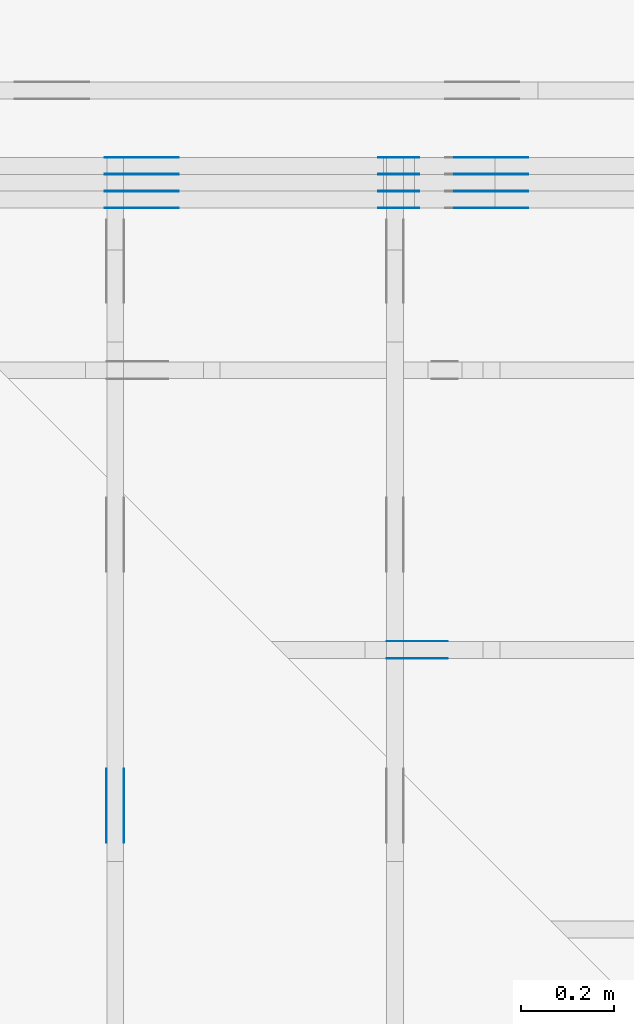
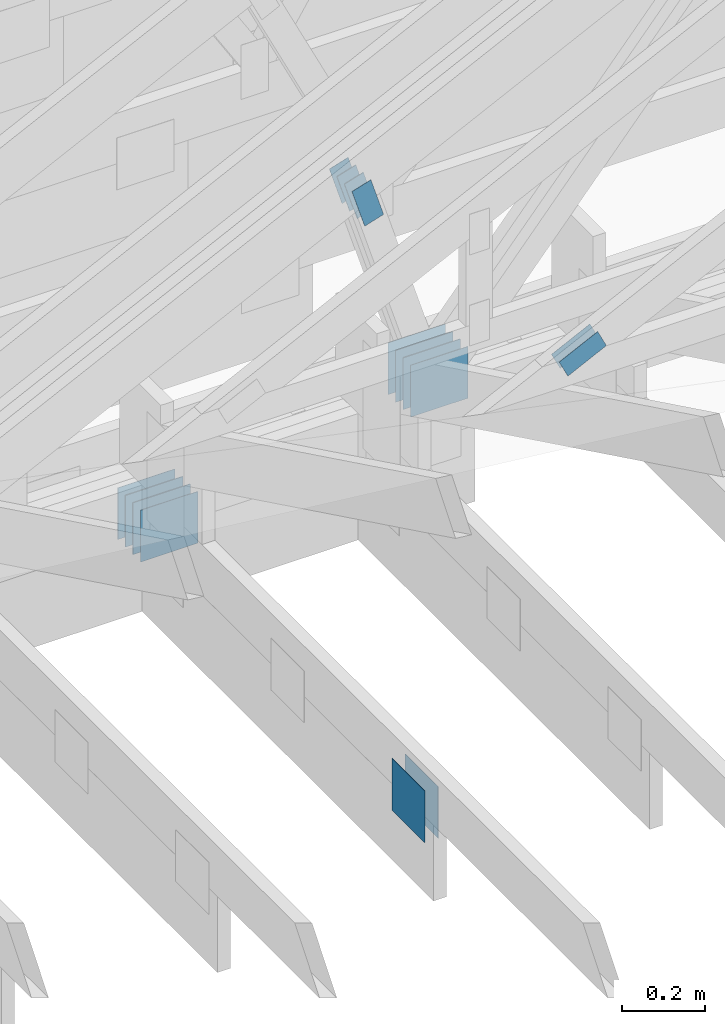
# One storey, part 99 of 159: 22 plates, 3 elements without a shape of their own.
"""IFC2X3 building model written with IfcOpenShell, lengths in millimetres."""

import ifcopenshell
import ifcopenshell.guid

model = None  # the IFC model being written
_history = None  # IfcOwnerHistory: only IFC2X3 demands one
_inside = {}  # id of a spatial element -> (the spatial element, [elements in it])
_under = {}  # id of a project, library or spatial element -> (it, [spatial elements below it])
_declared = {}  # id of a project -> (the project, [libraries it declares])
_typed = {}  # id of a type object -> (the type object, [elements of that type])
_made_of = {}  # id of a material, layer set ... -> (it, [elements and type objects made of it])


def new_model(schema):
    """Start an empty IFC model of exactly this schema.

    Asked for "IFC4X3", IfcOpenShell would pick the latest addendum, in which some entities
    have other attributes; the version numbers below select the first issue.
    IFC2X3 requires an IfcOwnerHistory on every rooted entity: one is made here for all.
    """
    global model, _history
    if schema == "IFC4X3":
        model = ifcopenshell.file(schema_version=(4, 3, 0, 0))
    else:
        model = ifcopenshell.file(schema=schema)
    _inside.clear()
    _under.clear()
    _declared.clear()
    _typed.clear()
    _made_of.clear()
    _history = None
    if model.schema == "IFC2X3":
        org = make("IfcOrganization", Name="unknown")
        user = make(
            "IfcPersonAndOrganization",
            ThePerson=make("IfcPerson", FamilyName="unknown"),
            TheOrganization=org,
        )
        app = make(
            "IfcApplication",
            ApplicationDeveloper=org,
            Version="unknown",
            ApplicationFullName="unknown",
            ApplicationIdentifier="unknown",
        )
        _history = make(
            "IfcOwnerHistory",
            OwningUser=user,
            OwningApplication=app,
            ChangeAction="ADDED",
            CreationDate=0,
        )
    return model


def make(cls, **values):
    """One entity of the class cls with the attributes given. An attribute that is None is left unset."""
    return model.create_entity(
        cls, **{name: value for name, value in values.items() if value is not None}
    )


def rooted(cls, **values):
    """An entity with a GlobalId (a new one), such as an element, a storey or a relation."""
    return make(cls, GlobalId=ifcopenshell.guid.new(), OwnerHistory=_history, **values)


def si_unit(unit_type, name, prefix=None):
    """IfcSIUnit, for example si_unit("LENGTHUNIT", "METRE", prefix="MILLI")."""
    return make("IfcSIUnit", UnitType=unit_type, Prefix=prefix, Name=name)


def assignment(units):
    """IfcUnitAssignment: the units of a project."""
    return None if units is None else make("IfcUnitAssignment", Units=units)


def point(xyz):
    """IfcCartesianPoint."""
    return None if xyz is None else make("IfcCartesianPoint", Coordinates=xyz)


def direction(xyz):
    """IfcDirection."""
    return None if xyz is None else make("IfcDirection", DirectionRatios=xyz)


def frame(location, z_axis=None, x_axis=None):
    """IfcAxis2Placement3D, a coordinate frame: its origin and axes. An axis left out is left unset."""
    return make(
        "IfcAxis2Placement3D",
        Location=point(location),
        Axis=direction(z_axis),
        RefDirection=direction(x_axis),
    )


def frame_2d(location, x_axis=None):
    """IfcAxis2Placement2D, a coordinate frame in the plane: its origin and x axis."""
    return make(
        "IfcAxis2Placement2D", Location=point(location), RefDirection=direction(x_axis)
    )


def origin():
    """The frame at (0, 0, 0) with its axes left unset."""
    return frame((0.0, 0.0, 0.0))


def origin_with_axes():
    """The frame at (0, 0, 0) with the z axis (0, 0, 1) and the x axis (1, 0, 0) written out."""
    return frame((0.0, 0.0, 0.0), z_axis=(0.0, 0.0, 1.0), x_axis=(1.0, 0.0, 0.0))


def origin_2d():
    """The frame at (0, 0) in the plane with its x axis left unset."""
    return frame_2d((0.0, 0.0))


def place(relative_to, where):
    """IfcLocalPlacement: puts the frame where relative to a parent placement (None: the world)."""
    return make(
        "IfcLocalPlacement", PlacementRelTo=relative_to, RelativePlacement=where
    )


def context(
    kind, dimensions, precision=None, world=None, true_north=None, identifier=None
):
    """IfcGeometricRepresentationContext, for example the 3D "Model" context."""
    return make(
        "IfcGeometricRepresentationContext",
        ContextIdentifier=identifier,
        ContextType=kind,
        CoordinateSpaceDimension=dimensions,
        Precision=precision,
        WorldCoordinateSystem=world,
        TrueNorth=true_north,
    )


def project(units=None, contexts=None):
    """IfcProject with its units and contexts."""
    return rooted(
        "IfcProject",
        Name="project",
        RepresentationContexts=contexts,
        UnitsInContext=assignment(units),
    )


def spatial(cls, under=None, at=None, **own):
    """A site, building, storey or space (cls), placed at a placement, below another one or the project."""
    s = rooted(cls, ObjectPlacement=at, **own)
    if under is not None:
        _under.setdefault(under.id(), (under, []))[1].append(s)
    return s


def faces_of(points, faces, orient=None, outer=None):
    """IfcFace entities. A face is a list of loops; a loop is a list of indices into points, from 0.

    orient and outer hold one flag for each loop. By default every Orientation is true, the
    first loop of a face is its IfcFaceOuterBound and the others are IfcFaceBound.
    """
    made = []
    for i, loops in enumerate(faces):
        bounds = []
        for j, loop in enumerate(loops):
            is_outer = j == 0 if outer is None else outer[i][j]
            bounds.append(
                make(
                    "IfcFaceOuterBound" if is_outer else "IfcFaceBound",
                    Bound=make("IfcPolyLoop", Polygon=[points[k] for k in loop]),
                    Orientation=True if orient is None else orient[i][j],
                )
            )
        made.append(make("IfcFace", Bounds=bounds))
    return made


def faceted_brep(points, faces, orient=None, outer=None, voids=None):
    """IfcFacetedBrep: a solid bounded by flat faces; with voids (closed shells), ...WithVoids."""
    shared = [point(p) for p in points]
    hull = make("IfcClosedShell", CfsFaces=faces_of(shared, faces, orient, outer))
    if voids is None:
        return make("IfcFacetedBrep", Outer=hull)
    return make(
        "IfcFacetedBrepWithVoids",
        Outer=hull,
        Voids=[
            make(cls, CfsFaces=faces_of(shared, fs, o, b)) for cls, fs, o, b in voids
        ],
    )


def shape(context_of_items, identifier, shape_type, items):
    """IfcShapeRepresentation: the items that make up one representation, for example the "Body"."""
    return make(
        "IfcShapeRepresentation",
        ContextOfItems=context_of_items,
        RepresentationIdentifier=identifier,
        RepresentationType=shape_type,
        Items=items,
    )


def made_of(thing, what):
    """Note that an element or type object is made of a material, layer set ...; save() writes the relation."""
    if what is not None:
        _made_of.setdefault(what.id(), (what, []))[1].append(thing)
    return thing


def element(
    cls,
    number,
    at=None,
    inside=None,
    cuts=None,
    type_object=None,
    material=None,
    context=None,
    identifier="Body",
    shape_type=None,
    held_by="IfcProductDefinitionShape",
    body=None,
    shapes=None,
    **own,
):
    """One element of the class cls, such as IfcWall. Its Tag is "e" and its number.

    at: its placement. inside: the storey or other place that contains it. cuts: it is an
    opening in that element (IfcRelVoidsElement). A single representation is given by context,
    identifier, shape_type and body (its items); several are given by shapes. held_by: the class
    of the entity that holds the representations. save() writes the other relations.
    """
    e = rooted(cls, Tag="e%d" % number, ObjectPlacement=at, **own)
    if body is not None:
        shapes = [shape(context, identifier, shape_type, body)]
    if shapes is not None:
        e.Representation = make(held_by, Representations=shapes)
    if inside is not None:
        _inside.setdefault(inside.id(), (inside, []))[1].append(e)
    if cuts is not None:
        rooted(
            "IfcRelVoidsElement", RelatingBuildingElement=cuts, RelatedOpeningElement=e
        )
    if type_object is not None:
        _typed.setdefault(type_object.id(), (type_object, []))[1].append(e)
    return made_of(e, material)


def aggregate(whole, parts):
    """IfcRelAggregates: a whole, such as a stair, and the parts it consists of."""
    return rooted("IfcRelAggregates", RelatingObject=whole, RelatedObjects=parts)


def save(model, path):
    """Write the relations noted so far, then the file.

    IfcRelAggregates (storeys below a building ...), IfcRelContainedInSpatialStructure (elements
    in a storey), IfcRelDefinesByType, IfcRelAssociatesMaterial and IfcRelDeclares: one each for
    every whole, place, type object, material and project.
    """
    for whole, parts in _under.values():
        aggregate(whole, parts)
    for where, things in _inside.values():
        rooted(
            "IfcRelContainedInSpatialStructure",
            RelatedElements=things,
            RelatingStructure=where,
        )
    for kind, things in _typed.values():
        rooted("IfcRelDefinesByType", RelatedObjects=things, RelatingType=kind)
    for what, things in _made_of.values():
        rooted("IfcRelAssociatesMaterial", RelatedObjects=things, RelatingMaterial=what)
    for by, libraries in _declared.values():
        rooted("IfcRelDeclares", RelatingContext=by, RelatedDefinitions=libraries)
    model.write(path)


model = new_model("IFC2X3")

# Units and contexts
model_context = context("Model", 3, precision=1e-05, world=origin())
plan_context = context("Plan", 2, precision=1e-05, world=origin_2d())
ifc_project = project(units=[si_unit("LENGTHUNIT", "METRE", prefix="MILLI"), si_unit("AREAUNIT", "SQUARE_METRE"), si_unit("VOLUMEUNIT", "CUBIC_METRE"), si_unit("SOLIDANGLEUNIT", "STERADIAN"), si_unit("PLANEANGLEUNIT", "RADIAN"), si_unit("MASSUNIT", "GRAM"), si_unit("TIMEUNIT", "SECOND"), si_unit("THERMODYNAMICTEMPERATUREUNIT", "DEGREE_CELSIUS"), si_unit("LUMINOUSINTENSITYUNIT", "LUMEN")], contexts=[model_context, plan_context])

# Site, building, storey
site_placement = place(None, origin_with_axes())
site = spatial("IfcSite", under=ifc_project, at=site_placement, CompositionType="ELEMENT")
building_placement = place(site_placement, origin_with_axes())
building = spatial("IfcBuilding", under=site, at=building_placement, Name="Plan 1", CompositionType="ELEMENT")
storey_placement = place(building_placement, origin_with_axes())
storey = spatial("IfcBuildingStorey", under=building, at=storey_placement, Name="Etasje 1", CompositionType="ELEMENT", Elevation=0.0)

# Assembly, plates
assembly_1_placement = place(storey_placement, frame((10700.012663101485, 8801.999999990367, 0.0), z_axis=(0.0, -1.0, 6.123031769111886e-17), x_axis=(1.0, 0.0, 0.0)))
assembly_1 = element("IfcElementAssembly", 1, at=assembly_1_placement, inside=storey, Name="T8 (1)", AssemblyPlace="FACTORY", PredefinedType="TRUSS")
plate_1_placement = place(assembly_1_placement, frame((1357.606207665543, 1028.988822678504, 0.0), z_axis=(0.0, 0.0, 1.0), x_axis=(0.29614145730451413, -0.9551440924099142, 0.0)))
plate_1 = element("IfcPlate", 2, at=plate_1_placement, Name="GNT100S 55x119", context=model_context, shape_type="Brep", body=[
    faceted_brep([(119.00002571171615, 55.00002869531636, 1.0), (0.0, 55.00002869531636, 1.0), (8.499032173858723e-05, 9.465324410484754e-05, 1.0), (119.00001625458845, 9.465324410484754e-05, 1.0), (0.0, 55.00002869531636, 0.0), (119.00002571171615, 55.00002869531636, 1.4572818759159385e-14), (119.00001625458845, 0.0, 1.4572817601033517e-14), (8.499032173858723e-05, 0.0, 1.0407968801448203e-20), (119.00004975672533, 5.067254458114396e-05, 1.3384475843434453e-30), (119.00004975672533, 5.067254458120519e-05, 1.0), (4.975672550244781e-05, 5.067254460306441e-05, 1.0), (4.975672550244781e-05, 5.067254460300318e-05, 3.76158192263132e-37), (119.00004975672533, 55.0000506725446, 0.0), (119.00004975672533, 55.0000506725446, 1.0), (119.00004975672533, 5.067254460300319e-05, 1.0), (119.00004975672533, 5.067254460300319e-05, 0.0), (4.975672527507413e-05, 55.00005067254483, 0.0), (4.975672527507413e-05, 55.00005067254483, 1.0), (119.00004975672533, 55.00005067254461, 1.0), (119.00004975672533, 55.00005067254461, 7.888609052210118e-31), (4.975672550244782e-05, 5.067254460300319e-05, -7.52316384526264e-37), (4.975672550250905e-05, 5.067254460300319e-05, 1.0), (4.975672528942023e-05, 55.00005067254483, 1.0), (4.9756725289359e-05, 55.00005067254483, -8.746667266163471e-31)], [[[0, 1, 2, 3]], [[4, 5, 6, 7]], [[8, 9, 10, 11]], [[12, 13, 14, 15]], [[16, 17, 18, 19]], [[20, 21, 22, 23]]]),
])
plate_2_placement = place(assembly_1_placement, frame((1357.606207665543, 1028.988822678504, -36.99999999999999), z_axis=(0.0, 0.0, 1.0), x_axis=(0.29614145730451413, -0.9551440924099142, 0.0)))
plate_2 = element("IfcPlate", 3, at=plate_2_placement, Name="GNT100S 55x119", context=model_context, shape_type="Brep", body=[
    faceted_brep([(119.00002571171615, 55.00002869531636, 1.0), (0.0, 55.00002869531636, 1.0), (8.499032173858723e-05, 9.465324410484754e-05, 1.0), (119.00001625458845, 9.465324410484754e-05, 1.0), (0.0, 55.00002869531636, 0.0), (119.00002571171615, 55.00002869531636, 1.4572818759159385e-14), (119.00001625458845, 0.0, 1.4572817601033517e-14), (8.499032173858723e-05, 0.0, 1.0407968801448203e-20), (119.00004975672533, 5.067254458114396e-05, 1.3384475843434453e-30), (119.00004975672533, 5.067254458120519e-05, 1.0), (4.975672550244781e-05, 5.067254460306441e-05, 1.0), (4.975672550244781e-05, 5.067254460300318e-05, 3.76158192263132e-37), (119.00004975672533, 55.0000506725446, 0.0), (119.00004975672533, 55.0000506725446, 1.0), (119.00004975672533, 5.067254460300319e-05, 1.0), (119.00004975672533, 5.067254460300319e-05, 0.0), (4.975672527507413e-05, 55.00005067254483, 0.0), (4.975672527507413e-05, 55.00005067254483, 1.0), (119.00004975672533, 55.00005067254461, 1.0), (119.00004975672533, 55.00005067254461, 7.888609052210118e-31), (4.975672550244782e-05, 5.067254460300319e-05, -7.52316384526264e-37), (4.975672550250905e-05, 5.067254460300319e-05, 1.0), (4.975672528942023e-05, 55.00005067254483, 1.0), (4.9756725289359e-05, 55.00005067254483, -8.746667266163471e-31)], [[[0, 1, 2, 3]], [[4, 5, 6, 7]], [[8, 9, 10, 11]], [[12, 13, 14, 15]], [[16, 17, 18, 19]], [[20, 21, 22, 23]]]),
])
plate_3_placement = place(assembly_1_placement, frame((1357.606207665543, 1028.988822678504, -36.0), z_axis=(0.0, 0.0, 1.0), x_axis=(0.29614145730451413, -0.9551440924099142, 0.0)))
plate_3 = element("IfcPlate", 4, at=plate_3_placement, Name="GNT100S 55x119", context=model_context, shape_type="Brep", body=[
    faceted_brep([(119.00002571171615, 55.00002869531636, 1.0), (0.0, 55.00002869531636, 1.0), (8.499032173858723e-05, 9.465324410484754e-05, 1.0), (119.00001625458845, 9.465324410484754e-05, 1.0), (0.0, 55.00002869531636, 0.0), (119.00002571171615, 55.00002869531636, 1.4572818759159385e-14), (119.00001625458845, 0.0, 1.4572817601033517e-14), (8.499032173858723e-05, 0.0, 1.0407968801448203e-20), (119.00004975672533, 5.067254458114396e-05, 1.3384475843434453e-30), (119.00004975672533, 5.067254458120519e-05, 1.0), (4.975672550244781e-05, 5.067254460306441e-05, 1.0), (4.975672550244781e-05, 5.067254460300318e-05, 3.76158192263132e-37), (119.00004975672533, 55.0000506725446, 0.0), (119.00004975672533, 55.0000506725446, 1.0), (119.00004975672533, 5.067254460300319e-05, 1.0), (119.00004975672533, 5.067254460300319e-05, 0.0), (4.975672527507413e-05, 55.00005067254483, 0.0), (4.975672527507413e-05, 55.00005067254483, 1.0), (119.00004975672533, 55.00005067254461, 1.0), (119.00004975672533, 55.00005067254461, 7.888609052210118e-31), (4.975672550244782e-05, 5.067254460300319e-05, -7.52316384526264e-37), (4.975672550250905e-05, 5.067254460300319e-05, 1.0), (4.975672528942023e-05, 55.00005067254483, 1.0), (4.9756725289359e-05, 55.00005067254483, -8.746667266163471e-31)], [[[0, 1, 2, 3]], [[4, 5, 6, 7]], [[8, 9, 10, 11]], [[12, 13, 14, 15]], [[16, 17, 18, 19]], [[20, 21, 22, 23]]]),
])
plate_4_placement = place(assembly_1_placement, frame((1357.606207665543, 1028.988822678504, -73.00000000000001), z_axis=(0.0, 0.0, 1.0), x_axis=(0.29614145730451413, -0.9551440924099142, 0.0)))
plate_4 = element("IfcPlate", 5, at=plate_4_placement, Name="GNT100S 55x119", context=model_context, shape_type="Brep", body=[
    faceted_brep([(119.00002571171615, 55.00002869531636, 1.0), (0.0, 55.00002869531636, 1.0), (8.499032173858723e-05, 9.465324410484754e-05, 1.0), (119.00001625458845, 9.465324410484754e-05, 1.0), (0.0, 55.00002869531636, 0.0), (119.00002571171615, 55.00002869531636, 1.4572818759159385e-14), (119.00001625458845, 0.0, 1.4572817601033517e-14), (8.499032173858723e-05, 0.0, 1.0407968801448203e-20), (119.00004975672533, 5.067254458114396e-05, 1.3384475843434453e-30), (119.00004975672533, 5.067254458120519e-05, 1.0), (4.975672550244781e-05, 5.067254460306441e-05, 1.0), (4.975672550244781e-05, 5.067254460300318e-05, 3.76158192263132e-37), (119.00004975672533, 55.0000506725446, 0.0), (119.00004975672533, 55.0000506725446, 1.0), (119.00004975672533, 5.067254460300319e-05, 1.0), (119.00004975672533, 5.067254460300319e-05, 0.0), (4.975672527507413e-05, 55.00005067254483, 0.0), (4.975672527507413e-05, 55.00005067254483, 1.0), (119.00004975672533, 55.00005067254461, 1.0), (119.00004975672533, 55.00005067254461, 7.888609052210118e-31), (4.975672550244782e-05, 5.067254460300319e-05, -7.52316384526264e-37), (4.975672550250905e-05, 5.067254460300319e-05, 1.0), (4.975672528942023e-05, 55.00005067254483, 1.0), (4.9756725289359e-05, 55.00005067254483, -8.746667266163471e-31)], [[[0, 1, 2, 3]], [[4, 5, 6, 7]], [[8, 9, 10, 11]], [[12, 13, 14, 15]], [[16, 17, 18, 19]], [[20, 21, 22, 23]]]),
])
plate_5_placement = place(assembly_1_placement, frame((1357.606207665543, 1028.988822678504, -72.0), z_axis=(0.0, 0.0, 1.0), x_axis=(0.29614145730451413, -0.9551440924099142, 0.0)))
plate_5 = element("IfcPlate", 6, at=plate_5_placement, Name="GNT100S 55x119", context=model_context, shape_type="Brep", body=[
    faceted_brep([(119.00002571171615, 55.00002869531636, 1.0), (0.0, 55.00002869531636, 1.0), (8.499032173858723e-05, 9.465324410484754e-05, 1.0), (119.00001625458845, 9.465324410484754e-05, 1.0), (0.0, 55.00002869531636, 0.0), (119.00002571171615, 55.00002869531636, 1.4572818759159385e-14), (119.00001625458845, 0.0, 1.4572817601033517e-14), (8.499032173858723e-05, 0.0, 1.0407968801448203e-20), (119.00004975672533, 5.067254458114396e-05, 1.3384475843434453e-30), (119.00004975672533, 5.067254458120519e-05, 1.0), (4.975672550244781e-05, 5.067254460306441e-05, 1.0), (4.975672550244781e-05, 5.067254460300318e-05, 3.76158192263132e-37), (119.00004975672533, 55.0000506725446, 0.0), (119.00004975672533, 55.0000506725446, 1.0), (119.00004975672533, 5.067254460300319e-05, 1.0), (119.00004975672533, 5.067254460300319e-05, 0.0), (4.975672527507413e-05, 55.00005067254483, 0.0), (4.975672527507413e-05, 55.00005067254483, 1.0), (119.00004975672533, 55.00005067254461, 1.0), (119.00004975672533, 55.00005067254461, 7.888609052210118e-31), (4.975672550244782e-05, 5.067254460300319e-05, -7.52316384526264e-37), (4.975672550250905e-05, 5.067254460300319e-05, 1.0), (4.975672528942023e-05, 55.00005067254483, 1.0), (4.9756725289359e-05, 55.00005067254483, -8.746667266163471e-31)], [[[0, 1, 2, 3]], [[4, 5, 6, 7]], [[8, 9, 10, 11]], [[12, 13, 14, 15]], [[16, 17, 18, 19]], [[20, 21, 22, 23]]]),
])
plate_6_placement = place(assembly_1_placement, frame((1357.606207665543, 1028.988822678504, -109.0), z_axis=(0.0, 0.0, 1.0), x_axis=(0.29614145730451413, -0.9551440924099142, 0.0)))
plate_6 = element("IfcPlate", 7, at=plate_6_placement, Name="GNT100S 55x119", context=model_context, shape_type="Brep", body=[
    faceted_brep([(119.00002571171615, 55.00002869531636, 1.0), (0.0, 55.00002869531636, 1.0), (8.499032173858723e-05, 9.465324410484754e-05, 1.0), (119.00001625458845, 9.465324410484754e-05, 1.0), (0.0, 55.00002869531636, 0.0), (119.00002571171615, 55.00002869531636, 1.4572818759159385e-14), (119.00001625458845, 0.0, 1.4572817601033517e-14), (8.499032173858723e-05, 0.0, 1.0407968801448203e-20), (119.00004975672533, 5.067254458114396e-05, 1.3384475843434453e-30), (119.00004975672533, 5.067254458120519e-05, 1.0), (4.975672550244781e-05, 5.067254460306441e-05, 1.0), (4.975672550244781e-05, 5.067254460300318e-05, 3.76158192263132e-37), (119.00004975672533, 55.0000506725446, 0.0), (119.00004975672533, 55.0000506725446, 1.0), (119.00004975672533, 5.067254460300319e-05, 1.0), (119.00004975672533, 5.067254460300319e-05, 0.0), (4.975672527507413e-05, 55.00005067254483, 0.0), (4.975672527507413e-05, 55.00005067254483, 1.0), (119.00004975672533, 55.00005067254461, 1.0), (119.00004975672533, 55.00005067254461, 7.888609052210118e-31), (4.975672550244782e-05, 5.067254460300319e-05, -7.52316384526264e-37), (4.975672550250905e-05, 5.067254460300319e-05, 1.0), (4.975672528942023e-05, 55.00005067254483, 1.0), (4.9756725289359e-05, 55.00005067254483, -8.746667266163471e-31)], [[[0, 1, 2, 3]], [[4, 5, 6, 7]], [[8, 9, 10, 11]], [[12, 13, 14, 15]], [[16, 17, 18, 19]], [[20, 21, 22, 23]]]),
])
plate_7_placement = place(assembly_1_placement, frame((1679.5000000000018, 462.0, 0.0), z_axis=(0.0, 0.0, 1.0), x_axis=(-1.0, 1.2246063538223773e-16, 0.0)))
plate_7 = element("IfcPlate", 8, at=plate_7_placement, Name="GNT100S 152x159", context=model_context, shape_type="Brep", body=[
    faceted_brep([(159.00000000000182, 152.0, 1.0), (1.8189894035458565e-12, 152.0, 1.0), (1.8189894035458565e-12, 0.0, 1.0), (159.00000000000182, 0.0, 1.0), (1.8189894035458565e-12, 152.0, 2.227545981117832e-28), (159.00000000000182, 152.0, 1.9471241025776022e-14), (159.00000000000182, 5.684341886080802e-14, 1.9471241025776022e-14), (1.8189894035458565e-12, 5.684341886080802e-14, 2.227545981117832e-28), (159.0, 1.4132339504376035e-13, 5.2688860062695115e-30), (159.0, 1.4138462536145147e-13, 1.0), (1.1247455413666031e-32, 1.7059148690011516e-13, 1.0), (0.0, 1.7053025658242404e-13, 0.0), (159.0, 152.00000000000023, 0.0), (159.0, 152.00000000000023, 1.0), (159.0, 2.2737367544323206e-13, 1.0), (159.0, 2.2737367544323206e-13, 0.0), (0.0, 152.00000000000017, 0.0), (0.0, 152.00000000000017, 1.0), (159.0, 152.00000000000023, 1.0), (159.0, 152.00000000000023, 0.0), (2.0883243572979676e-29, 1.7053025658242404e-13, -1.2786876383945617e-45), (6.123031769113974e-17, 1.7053025658242404e-13, 1.0), (1.8675246895791275e-14, 152.00000000000017, 1.0), (1.8614016578100156e-14, 152.00000000000017, -1.1397421485848257e-30)], [[[0, 1, 2, 3]], [[4, 5, 6, 7]], [[8, 9, 10, 11]], [[12, 13, 14, 15]], [[16, 17, 18, 19]], [[20, 21, 22, 23]]]),
])
plate_8_placement = place(assembly_1_placement, frame((1679.5000000000018, 462.0, -37.0), z_axis=(0.0, 0.0, 1.0), x_axis=(-1.0, 1.2246063538223773e-16, 0.0)))
plate_8 = element("IfcPlate", 9, at=plate_8_placement, Name="GNT100S 152x159", context=model_context, shape_type="Brep", body=[
    faceted_brep([(159.00000000000182, 152.0, 1.0), (1.8189894035458565e-12, 152.0, 1.0), (1.8189894035458565e-12, 0.0, 1.0), (159.00000000000182, 0.0, 1.0), (1.8189894035458565e-12, 152.0, 2.227545981117832e-28), (159.00000000000182, 152.0, 1.9471241025776022e-14), (159.00000000000182, 5.684341886080802e-14, 1.9471241025776022e-14), (1.8189894035458565e-12, 5.684341886080802e-14, 2.227545981117832e-28), (159.0, 1.4132339504376035e-13, 5.2688860062695115e-30), (159.0, 1.4138462536145147e-13, 1.0), (1.1247455413666031e-32, 1.7059148690011516e-13, 1.0), (0.0, 1.7053025658242404e-13, 0.0), (159.0, 152.00000000000023, 0.0), (159.0, 152.00000000000023, 1.0), (159.0, 2.2737367544323206e-13, 1.0), (159.0, 2.2737367544323206e-13, 0.0), (0.0, 152.00000000000017, 0.0), (0.0, 152.00000000000017, 1.0), (159.0, 152.00000000000023, 1.0), (159.0, 152.00000000000023, 0.0), (2.0883243572979676e-29, 1.7053025658242404e-13, -1.2786876383945617e-45), (6.123031769113974e-17, 1.7053025658242404e-13, 1.0), (1.8675246895791275e-14, 152.00000000000017, 1.0), (1.8614016578100156e-14, 152.00000000000017, -1.1397421485848257e-30)], [[[0, 1, 2, 3]], [[4, 5, 6, 7]], [[8, 9, 10, 11]], [[12, 13, 14, 15]], [[16, 17, 18, 19]], [[20, 21, 22, 23]]]),
])
plate_9_placement = place(assembly_1_placement, frame((1679.5000000000018, 462.0, -36.0), z_axis=(0.0, 0.0, 1.0), x_axis=(-1.0, 1.2246063538223773e-16, 0.0)))
plate_9 = element("IfcPlate", 10, at=plate_9_placement, Name="GNT100S 152x159", context=model_context, shape_type="Brep", body=[
    faceted_brep([(159.00000000000182, 152.0, 1.0), (1.8189894035458565e-12, 152.0, 1.0), (1.8189894035458565e-12, 0.0, 1.0), (159.00000000000182, 0.0, 1.0), (1.8189894035458565e-12, 152.0, 2.227545981117832e-28), (159.00000000000182, 152.0, 1.9471241025776022e-14), (159.00000000000182, 5.684341886080802e-14, 1.9471241025776022e-14), (1.8189894035458565e-12, 5.684341886080802e-14, 2.227545981117832e-28), (159.0, 1.4132339504376035e-13, 5.2688860062695115e-30), (159.0, 1.4138462536145147e-13, 1.0), (1.1247455413666031e-32, 1.7059148690011516e-13, 1.0), (0.0, 1.7053025658242404e-13, 0.0), (159.0, 152.00000000000023, 0.0), (159.0, 152.00000000000023, 1.0), (159.0, 2.2737367544323206e-13, 1.0), (159.0, 2.2737367544323206e-13, 0.0), (0.0, 152.00000000000017, 0.0), (0.0, 152.00000000000017, 1.0), (159.0, 152.00000000000023, 1.0), (159.0, 152.00000000000023, 0.0), (2.0883243572979676e-29, 1.7053025658242404e-13, -1.2786876383945617e-45), (6.123031769113974e-17, 1.7053025658242404e-13, 1.0), (1.8675246895791275e-14, 152.00000000000017, 1.0), (1.8614016578100156e-14, 152.00000000000017, -1.1397421485848257e-30)], [[[0, 1, 2, 3]], [[4, 5, 6, 7]], [[8, 9, 10, 11]], [[12, 13, 14, 15]], [[16, 17, 18, 19]], [[20, 21, 22, 23]]]),
])
plate_10_placement = place(assembly_1_placement, frame((1679.5000000000018, 462.0, -73.0), z_axis=(0.0, 0.0, 1.0), x_axis=(-1.0, 1.2246063538223773e-16, 0.0)))
plate_10 = element("IfcPlate", 11, at=plate_10_placement, Name="GNT100S 152x159", context=model_context, shape_type="Brep", body=[
    faceted_brep([(159.00000000000182, 152.0, 1.0), (1.8189894035458565e-12, 152.0, 1.0), (1.8189894035458565e-12, 0.0, 1.0), (159.00000000000182, 0.0, 1.0), (1.8189894035458565e-12, 152.0, 2.227545981117832e-28), (159.00000000000182, 152.0, 1.9471241025776022e-14), (159.00000000000182, 5.684341886080802e-14, 1.9471241025776022e-14), (1.8189894035458565e-12, 5.684341886080802e-14, 2.227545981117832e-28), (159.0, 1.4132339504376035e-13, 5.2688860062695115e-30), (159.0, 1.4138462536145147e-13, 1.0), (1.1247455413666031e-32, 1.7059148690011516e-13, 1.0), (0.0, 1.7053025658242404e-13, 0.0), (159.0, 152.00000000000023, 0.0), (159.0, 152.00000000000023, 1.0), (159.0, 2.2737367544323206e-13, 1.0), (159.0, 2.2737367544323206e-13, 0.0), (0.0, 152.00000000000017, 0.0), (0.0, 152.00000000000017, 1.0), (159.0, 152.00000000000023, 1.0), (159.0, 152.00000000000023, 0.0), (2.0883243572979676e-29, 1.7053025658242404e-13, -1.2786876383945617e-45), (6.123031769113974e-17, 1.7053025658242404e-13, 1.0), (1.8675246895791275e-14, 152.00000000000017, 1.0), (1.8614016578100156e-14, 152.00000000000017, -1.1397421485848257e-30)], [[[0, 1, 2, 3]], [[4, 5, 6, 7]], [[8, 9, 10, 11]], [[12, 13, 14, 15]], [[16, 17, 18, 19]], [[20, 21, 22, 23]]]),
])
plate_11_placement = place(assembly_1_placement, frame((1679.5000000000018, 462.0, -72.0), z_axis=(0.0, 0.0, 1.0), x_axis=(-1.0, 1.2246063538223773e-16, 0.0)))
plate_11 = element("IfcPlate", 12, at=plate_11_placement, Name="GNT100S 152x159", context=model_context, shape_type="Brep", body=[
    faceted_brep([(159.00000000000182, 152.0, 1.0), (1.8189894035458565e-12, 152.0, 1.0), (1.8189894035458565e-12, 0.0, 1.0), (159.00000000000182, 0.0, 1.0), (1.8189894035458565e-12, 152.0, 2.227545981117832e-28), (159.00000000000182, 152.0, 1.9471241025776022e-14), (159.00000000000182, 5.684341886080802e-14, 1.9471241025776022e-14), (1.8189894035458565e-12, 5.684341886080802e-14, 2.227545981117832e-28), (159.0, 1.4132339504376035e-13, 5.2688860062695115e-30), (159.0, 1.4138462536145147e-13, 1.0), (1.1247455413666031e-32, 1.7059148690011516e-13, 1.0), (0.0, 1.7053025658242404e-13, 0.0), (159.0, 152.00000000000023, 0.0), (159.0, 152.00000000000023, 1.0), (159.0, 2.2737367544323206e-13, 1.0), (159.0, 2.2737367544323206e-13, 0.0), (0.0, 152.00000000000017, 0.0), (0.0, 152.00000000000017, 1.0), (159.0, 152.00000000000023, 1.0), (159.0, 152.00000000000023, 0.0), (2.0883243572979676e-29, 1.7053025658242404e-13, -1.2786876383945617e-45), (6.123031769113974e-17, 1.7053025658242404e-13, 1.0), (1.8675246895791275e-14, 152.00000000000017, 1.0), (1.8614016578100156e-14, 152.00000000000017, -1.1397421485848257e-30)], [[[0, 1, 2, 3]], [[4, 5, 6, 7]], [[8, 9, 10, 11]], [[12, 13, 14, 15]], [[16, 17, 18, 19]], [[20, 21, 22, 23]]]),
])
plate_12_placement = place(assembly_1_placement, frame((1679.5000000000018, 462.0, -109.0), z_axis=(0.0, 0.0, 1.0), x_axis=(-1.0, 1.2246063538223773e-16, 0.0)))
plate_12 = element("IfcPlate", 13, at=plate_12_placement, Name="GNT100S 152x159", context=model_context, shape_type="Brep", body=[
    faceted_brep([(159.00000000000182, 152.0, 1.0), (1.8189894035458565e-12, 152.0, 1.0), (1.8189894035458565e-12, 0.0, 1.0), (159.00000000000182, 0.0, 1.0), (1.8189894035458565e-12, 152.0, 2.227545981117832e-28), (159.00000000000182, 152.0, 1.9471241025776022e-14), (159.00000000000182, 5.684341886080802e-14, 1.9471241025776022e-14), (1.8189894035458565e-12, 5.684341886080802e-14, 2.227545981117832e-28), (159.0, 1.4132339504376035e-13, 5.2688860062695115e-30), (159.0, 1.4138462536145147e-13, 1.0), (1.1247455413666031e-32, 1.7059148690011516e-13, 1.0), (0.0, 1.7053025658242404e-13, 0.0), (159.0, 152.00000000000023, 0.0), (159.0, 152.00000000000023, 1.0), (159.0, 2.2737367544323206e-13, 1.0), (159.0, 2.2737367544323206e-13, 0.0), (0.0, 152.00000000000017, 0.0), (0.0, 152.00000000000017, 1.0), (159.0, 152.00000000000023, 1.0), (159.0, 152.00000000000023, 0.0), (2.0883243572979676e-29, 1.7053025658242404e-13, -1.2786876383945617e-45), (6.123031769113974e-17, 1.7053025658242404e-13, 1.0), (1.8675246895791275e-14, 152.00000000000017, 1.0), (1.8614016578100156e-14, 152.00000000000017, -1.1397421485848257e-30)], [[[0, 1, 2, 3]], [[4, 5, 6, 7]], [[8, 9, 10, 11]], [[12, 13, 14, 15]], [[16, 17, 18, 19]], [[20, 21, 22, 23]]]),
])
plate_13_placement = place(assembly_1_placement, frame((770.5, 147.0, 0.0), z_axis=(0.0, 0.0, 1.0), x_axis=(1.0, 0.0, 0.0)))
plate_13 = element("IfcPlate", 14, at=plate_13_placement, Name="GNT100S 152x159", context=model_context, shape_type="Brep", body=[
    faceted_brep([(159.0, 152.0, 1.0), (0.0, 152.0, 1.0), (0.0, 0.0, 1.0), (159.0, 0.0, 1.0), (0.0, 152.0, 0.0), (159.0, 152.0, 1.9471241025775798e-14), (159.0, 0.0, 1.9471241025775798e-14), (0.0, 0.0, 0.0), (159.0, -2.92068615386637e-14, 1.788345410772899e-30), (159.0, -2.914563122097258e-14, 1.0), (1.1247455413666031e-32, 6.123031769111886e-17, 1.0), (0.0, 0.0, 0.0), (159.0, 152.0, 0.0), (159.0, 152.0, 1.0), (159.0, 0.0, 1.0), (159.0, 0.0, 0.0), (0.0, 152.0, 0.0), (-3.7491518045553436e-33, 152.0, 1.0), (159.0, 152.0, 1.0), (159.0, 152.0, 0.0), (0.0, 0.0, 0.0), (6.123031769111886e-17, -7.498303609110687e-33, 1.0), (1.8675246895791253e-14, 152.0, 1.0), (1.8614016578100134e-14, 152.0, -1.1397421485848245e-30)], [[[0, 1, 2, 3]], [[4, 5, 6, 7]], [[8, 9, 10, 11]], [[12, 13, 14, 15]], [[16, 17, 18, 19]], [[20, 21, 22, 23]]]),
])
plate_14_placement = place(assembly_1_placement, frame((770.5, 147.0, -37.0), z_axis=(0.0, 0.0, 1.0), x_axis=(1.0, 0.0, 0.0)))
plate_14 = element("IfcPlate", 15, at=plate_14_placement, Name="GNT100S 152x159", context=model_context, shape_type="Brep", body=[
    faceted_brep([(159.0, 152.0, 1.0), (0.0, 152.0, 1.0), (0.0, 0.0, 1.0), (159.0, 0.0, 1.0), (0.0, 152.0, 0.0), (159.0, 152.0, 1.9471241025775798e-14), (159.0, 0.0, 1.9471241025775798e-14), (0.0, 0.0, 0.0), (159.0, -2.92068615386637e-14, 1.788345410772899e-30), (159.0, -2.914563122097258e-14, 1.0), (1.1247455413666031e-32, 6.123031769111886e-17, 1.0), (0.0, 0.0, 0.0), (159.0, 152.0, 0.0), (159.0, 152.0, 1.0), (159.0, 0.0, 1.0), (159.0, 0.0, 0.0), (0.0, 152.0, 0.0), (-3.7491518045553436e-33, 152.0, 1.0), (159.0, 152.0, 1.0), (159.0, 152.0, 0.0), (0.0, 0.0, 0.0), (6.123031769111886e-17, -7.498303609110687e-33, 1.0), (1.8675246895791253e-14, 152.0, 1.0), (1.8614016578100134e-14, 152.0, -1.1397421485848245e-30)], [[[0, 1, 2, 3]], [[4, 5, 6, 7]], [[8, 9, 10, 11]], [[12, 13, 14, 15]], [[16, 17, 18, 19]], [[20, 21, 22, 23]]]),
])
plate_15_placement = place(assembly_1_placement, frame((770.5, 147.0, -36.0), z_axis=(0.0, 0.0, 1.0), x_axis=(1.0, 0.0, 0.0)))
plate_15 = element("IfcPlate", 16, at=plate_15_placement, Name="GNT100S 152x159", context=model_context, shape_type="Brep", body=[
    faceted_brep([(159.0, 152.0, 1.0), (0.0, 152.0, 1.0), (0.0, 0.0, 1.0), (159.0, 0.0, 1.0), (0.0, 152.0, 0.0), (159.0, 152.0, 1.9471241025775798e-14), (159.0, 0.0, 1.9471241025775798e-14), (0.0, 0.0, 0.0), (159.0, -2.92068615386637e-14, 1.788345410772899e-30), (159.0, -2.914563122097258e-14, 1.0), (1.1247455413666031e-32, 6.123031769111886e-17, 1.0), (0.0, 0.0, 0.0), (159.0, 152.0, 0.0), (159.0, 152.0, 1.0), (159.0, 0.0, 1.0), (159.0, 0.0, 0.0), (0.0, 152.0, 0.0), (-3.7491518045553436e-33, 152.0, 1.0), (159.0, 152.0, 1.0), (159.0, 152.0, 0.0), (0.0, 0.0, 0.0), (6.123031769111886e-17, -7.498303609110687e-33, 1.0), (1.8675246895791253e-14, 152.0, 1.0), (1.8614016578100134e-14, 152.0, -1.1397421485848245e-30)], [[[0, 1, 2, 3]], [[4, 5, 6, 7]], [[8, 9, 10, 11]], [[12, 13, 14, 15]], [[16, 17, 18, 19]], [[20, 21, 22, 23]]]),
])
plate_16_placement = place(assembly_1_placement, frame((770.5, 147.0, -73.0), z_axis=(0.0, 0.0, 1.0), x_axis=(1.0, 0.0, 0.0)))
plate_16 = element("IfcPlate", 17, at=plate_16_placement, Name="GNT100S 152x159", context=model_context, shape_type="Brep", body=[
    faceted_brep([(159.0, 152.0, 1.0), (0.0, 152.0, 1.0), (0.0, 0.0, 1.0), (159.0, 0.0, 1.0), (0.0, 152.0, 0.0), (159.0, 152.0, 1.9471241025775798e-14), (159.0, 0.0, 1.9471241025775798e-14), (0.0, 0.0, 0.0), (159.0, -2.92068615386637e-14, 1.788345410772899e-30), (159.0, -2.914563122097258e-14, 1.0), (1.1247455413666031e-32, 6.123031769111886e-17, 1.0), (0.0, 0.0, 0.0), (159.0, 152.0, 0.0), (159.0, 152.0, 1.0), (159.0, 0.0, 1.0), (159.0, 0.0, 0.0), (0.0, 152.0, 0.0), (-3.7491518045553436e-33, 152.0, 1.0), (159.0, 152.0, 1.0), (159.0, 152.0, 0.0), (0.0, 0.0, 0.0), (6.123031769111886e-17, -7.498303609110687e-33, 1.0), (1.8675246895791253e-14, 152.0, 1.0), (1.8614016578100134e-14, 152.0, -1.1397421485848245e-30)], [[[0, 1, 2, 3]], [[4, 5, 6, 7]], [[8, 9, 10, 11]], [[12, 13, 14, 15]], [[16, 17, 18, 19]], [[20, 21, 22, 23]]]),
])
plate_17_placement = place(assembly_1_placement, frame((770.5, 147.0, -72.0), z_axis=(0.0, 0.0, 1.0), x_axis=(1.0, 0.0, 0.0)))
plate_17 = element("IfcPlate", 18, at=plate_17_placement, Name="GNT100S 152x159", context=model_context, shape_type="Brep", body=[
    faceted_brep([(159.0, 152.0, 1.0), (0.0, 152.0, 1.0), (0.0, 0.0, 1.0), (159.0, 0.0, 1.0), (0.0, 152.0, 0.0), (159.0, 152.0, 1.9471241025775798e-14), (159.0, 0.0, 1.9471241025775798e-14), (0.0, 0.0, 0.0), (159.0, -2.92068615386637e-14, 1.788345410772899e-30), (159.0, -2.914563122097258e-14, 1.0), (1.1247455413666031e-32, 6.123031769111886e-17, 1.0), (0.0, 0.0, 0.0), (159.0, 152.0, 0.0), (159.0, 152.0, 1.0), (159.0, 0.0, 1.0), (159.0, 0.0, 0.0), (0.0, 152.0, 0.0), (-3.7491518045553436e-33, 152.0, 1.0), (159.0, 152.0, 1.0), (159.0, 152.0, 0.0), (0.0, 0.0, 0.0), (6.123031769111886e-17, -7.498303609110687e-33, 1.0), (1.8675246895791253e-14, 152.0, 1.0), (1.8614016578100134e-14, 152.0, -1.1397421485848245e-30)], [[[0, 1, 2, 3]], [[4, 5, 6, 7]], [[8, 9, 10, 11]], [[12, 13, 14, 15]], [[16, 17, 18, 19]], [[20, 21, 22, 23]]]),
])
plate_18_placement = place(assembly_1_placement, frame((770.5, 147.0, -109.0), z_axis=(0.0, 0.0, 1.0), x_axis=(1.0, 0.0, 0.0)))
plate_18 = element("IfcPlate", 19, at=plate_18_placement, Name="GNT100S 152x159", context=model_context, shape_type="Brep", body=[
    faceted_brep([(159.0, 152.0, 1.0), (0.0, 152.0, 1.0), (0.0, 0.0, 1.0), (159.0, 0.0, 1.0), (0.0, 152.0, 0.0), (159.0, 152.0, 1.9471241025775798e-14), (159.0, 0.0, 1.9471241025775798e-14), (0.0, 0.0, 0.0), (159.0, -2.92068615386637e-14, 1.788345410772899e-30), (159.0, -2.914563122097258e-14, 1.0), (1.1247455413666031e-32, 6.123031769111886e-17, 1.0), (0.0, 0.0, 0.0), (159.0, 152.0, 0.0), (159.0, 152.0, 1.0), (159.0, 0.0, 1.0), (159.0, 0.0, 0.0), (0.0, 152.0, 0.0), (-3.7491518045553436e-33, 152.0, 1.0), (159.0, 152.0, 1.0), (159.0, 152.0, 0.0), (0.0, 0.0, 0.0), (6.123031769111886e-17, -7.498303609110687e-33, 1.0), (1.8675246895791253e-14, 152.0, 1.0), (1.8614016578100134e-14, 152.0, -1.1397421485848245e-30)], [[[0, 1, 2, 3]], [[4, 5, 6, 7]], [[8, 9, 10, 11]], [[12, 13, 14, 15]], [[16, 17, 18, 19]], [[20, 21, 22, 23]]]),
])
aggregate(assembly_1, [plate_1, plate_2, plate_3, plate_4, plate_5, plate_6, plate_7, plate_8, plate_9, plate_10, plate_11, plate_12, plate_13, plate_14, plate_15, plate_16, plate_17, plate_18])

assembly_2_placement = place(storey_placement, frame((11475.022261404752, -699.9989301294845, 1.1021457184401395e-15), z_axis=(-1.0, 1.836909530733566e-16, 6.123031769111886e-17), x_axis=(-1.836909530733566e-16, -1.0, 0.0)))
assembly_2 = element("IfcElementAssembly", 20, at=assembly_2_placement, inside=storey, Name="T5 (97)", AssemblyPlace="FACTORY", PredefinedType="TRUSS")
plate_19_placement = place(assembly_2_placement, frame((-8139.998930119909, 299.0, 0.0), z_axis=(0.0, 0.0, 1.0), x_axis=(-1.0, 1.2246063538223773e-16, 0.0)))
plate_19 = element("IfcPlate", 21, at=plate_19_placement, Name="GNT100S 152x159", context=model_context, shape_type="Brep", body=[
    faceted_brep([(159.00009331759065, 151.99999999999997, 1.0), (9.331759065389633e-05, 151.99999999999997, 1.0), (9.331759065389633e-05, 0.0, 1.0), (159.00009331759065, 0.0, 1.0), (9.331759065389633e-05, 151.99999999999997, 1.1427731443815714e-20), (159.00009331759065, 151.99999999999997, 1.9471252453507242e-14), (159.00009331759065, 0.0, 1.9471252453507242e-14), (9.331759065389633e-05, 0.0, 1.1427731443815714e-20), (159.0, -2.92068615386637e-14, 1.788345410772899e-30), (159.0, -2.914563122097258e-14, 1.0), (1.1247455413666031e-32, 6.123031769111886e-17, 1.0), (0.0, 0.0, 0.0), (159.0, 152.0, 0.0), (159.0, 152.0, 1.0), (159.0, 0.0, 1.0), (159.0, 0.0, 0.0), (0.0, 151.99999999999997, 0.0), (0.0, 151.99999999999997, 1.0), (159.0, 152.0, 1.0), (159.0, 152.0, 0.0), (0.0, 0.0, 0.0), (6.123031769111886e-17, -7.498303609110687e-33, 1.0), (1.867524689579125e-14, 151.99999999999997, 1.0), (1.861401657810013e-14, 151.99999999999997, -1.1397421485848243e-30)], [[[0, 1, 2, 3]], [[4, 5, 6, 7]], [[8, 9, 10, 11]], [[12, 13, 14, 15]], [[16, 17, 18, 19]], [[20, 21, 22, 23]]]),
])
plate_20_placement = place(assembly_2_placement, frame((-8139.998930119909, 299.0, -37.0), z_axis=(0.0, 0.0, 1.0), x_axis=(-1.0, 1.2246063538223773e-16, 0.0)))
plate_20 = element("IfcPlate", 22, at=plate_20_placement, Name="GNT100S 152x159", context=model_context, shape_type="Brep", body=[
    faceted_brep([(159.00009331759065, 151.99999999999997, 1.0), (9.331759065389633e-05, 151.99999999999997, 1.0), (9.331759065389633e-05, 0.0, 1.0), (159.00009331759065, 0.0, 1.0), (9.331759065389633e-05, 151.99999999999997, 1.1427731443815714e-20), (159.00009331759065, 151.99999999999997, 1.9471252453507242e-14), (159.00009331759065, 0.0, 1.9471252453507242e-14), (9.331759065389633e-05, 0.0, 1.1427731443815714e-20), (159.0, -2.92068615386637e-14, 1.788345410772899e-30), (159.0, -2.914563122097258e-14, 1.0), (1.1247455413666031e-32, 6.123031769111886e-17, 1.0), (0.0, 0.0, 0.0), (159.0, 152.0, 0.0), (159.0, 152.0, 1.0), (159.0, 0.0, 1.0), (159.0, 0.0, 0.0), (0.0, 151.99999999999997, 0.0), (0.0, 151.99999999999997, 1.0), (159.0, 152.0, 1.0), (159.0, 152.0, 0.0), (0.0, 0.0, 0.0), (6.123031769111886e-17, -7.498303609110687e-33, 1.0), (1.867524689579125e-14, 151.99999999999997, 1.0), (1.861401657810013e-14, 151.99999999999997, -1.1397421485848243e-30)], [[[0, 1, 2, 3]], [[4, 5, 6, 7]], [[8, 9, 10, 11]], [[12, 13, 14, 15]], [[16, 17, 18, 19]], [[20, 21, 22, 23]]]),
])
aggregate(assembly_2, [plate_19, plate_20])

assembly_3_placement = place(storey_placement, frame((11846.012601162385, 7836.000061939094, 1020.3543282828622), z_axis=(0.0, -1.0, 6.123031769111886e-17), x_axis=(1.0, 0.0, 0.0)))
assembly_3 = element("IfcElementAssembly", 23, at=assembly_3_placement, inside=storey, Name="Tr2 (1)", AssemblyPlace="FACTORY", PredefinedType="TRUSS")
plate_21_placement = place(assembly_3_placement, frame((253.2841968538207, 38.42090597057235, 0.0), z_axis=(0.0, 0.0, 1.0), x_axis=(0.898794046299167, 0.4383711467890774, 0.0)))
plate_21 = element("IfcPlate", 24, at=plate_21_placement, Name="GNT100S 55x119", context=model_context, shape_type="Brep", body=[
    faceted_brep([(119.00000687542453, 55.00000532224293, 1.0), (1.0028205394974066e-06, 55.00000532224293, 1.0), (0.0, 4.3514078242878895e-06, 1.0), (119.00000420035079, 4.3514078242878895e-06, 1.0), (1.0028205394974066e-06, 55.00000532224293, 1.2280604044121083e-22), (119.00000687542453, 55.00000532224293, 1.4572816452455147e-14), (119.00000420035079, 0.0, 1.4572816124863917e-14), (0.0, 0.0, 0.0), (119.00000339051402, 2.2986236908450607e-06, 4.683120593110999e-31), (119.00000339051402, 2.298623690906291e-06, 1.0), (3.3905140242040943e-06, 2.2986237127655144e-06, 1.0), (3.3905140242040943e-06, 2.298623712704284e-06, 2.350988701644575e-38), (119.00000339051402, 55.0000022986237, 3.1554436208840472e-30), (119.00000339051402, 55.0000022986237, 1.0), (119.00000339051402, 2.2986236984934294e-06, 1.0), (119.00000339051402, 2.2986236984934294e-06, 0.0), (3.3905140242040943e-06, 55.0000022986237, 0.0), (3.3905140242040943e-06, 55.0000022986237, 1.0), (119.00000339051397, 55.00000229862369, 1.0), (119.00000339051397, 55.00000229862369, -3.944304526105059e-31), (3.3905140242040947e-06, 2.298623712704284e-06, -2.350988701644575e-38), (3.390514024265325e-06, 2.298623712704284e-06, 1.0), (3.39051403100066e-06, 55.0000022986237, 1.0), (3.3905140309394297e-06, 55.0000022986237, -4.1240672348034275e-31)], [[[0, 1, 2, 3]], [[4, 5, 6, 7]], [[8, 9, 10, 11]], [[12, 13, 14, 15]], [[16, 17, 18, 19]], [[20, 21, 22, 23]]]),
])
plate_22_placement = place(assembly_3_placement, frame((253.2841968538207, 38.42090597057235, -37.00000000000001), z_axis=(0.0, 0.0, 1.0), x_axis=(0.898794046299167, 0.4383711467890774, 0.0)))
plate_22 = element("IfcPlate", 25, at=plate_22_placement, Name="GNT100S 55x119", context=model_context, shape_type="Brep", body=[
    faceted_brep([(119.00000687542453, 55.00000532224293, 1.0), (1.0028205394974066e-06, 55.00000532224293, 1.0), (0.0, 4.3514078242878895e-06, 1.0), (119.00000420035079, 4.3514078242878895e-06, 1.0), (1.0028205394974066e-06, 55.00000532224293, 1.2280604044121083e-22), (119.00000687542453, 55.00000532224293, 1.4572816452455147e-14), (119.00000420035079, 0.0, 1.4572816124863917e-14), (0.0, 0.0, 0.0), (119.00000339051402, 2.2986236908450607e-06, 4.683120593110999e-31), (119.00000339051402, 2.298623690906291e-06, 1.0), (3.3905140242040943e-06, 2.2986237127655144e-06, 1.0), (3.3905140242040943e-06, 2.298623712704284e-06, 2.350988701644575e-38), (119.00000339051402, 55.0000022986237, 3.1554436208840472e-30), (119.00000339051402, 55.0000022986237, 1.0), (119.00000339051402, 2.2986236984934294e-06, 1.0), (119.00000339051402, 2.2986236984934294e-06, 0.0), (3.3905140242040943e-06, 55.0000022986237, 0.0), (3.3905140242040943e-06, 55.0000022986237, 1.0), (119.00000339051397, 55.00000229862369, 1.0), (119.00000339051397, 55.00000229862369, -3.944304526105059e-31), (3.3905140242040947e-06, 2.298623712704284e-06, -2.350988701644575e-38), (3.390514024265325e-06, 2.298623712704284e-06, 1.0), (3.39051403100066e-06, 55.0000022986237, 1.0), (3.3905140309394297e-06, 55.0000022986237, -4.1240672348034275e-31)], [[[0, 1, 2, 3]], [[4, 5, 6, 7]], [[8, 9, 10, 11]], [[12, 13, 14, 15]], [[16, 17, 18, 19]], [[20, 21, 22, 23]]]),
])
aggregate(assembly_3, [plate_21, plate_22])

save(model, "model.ifc")
